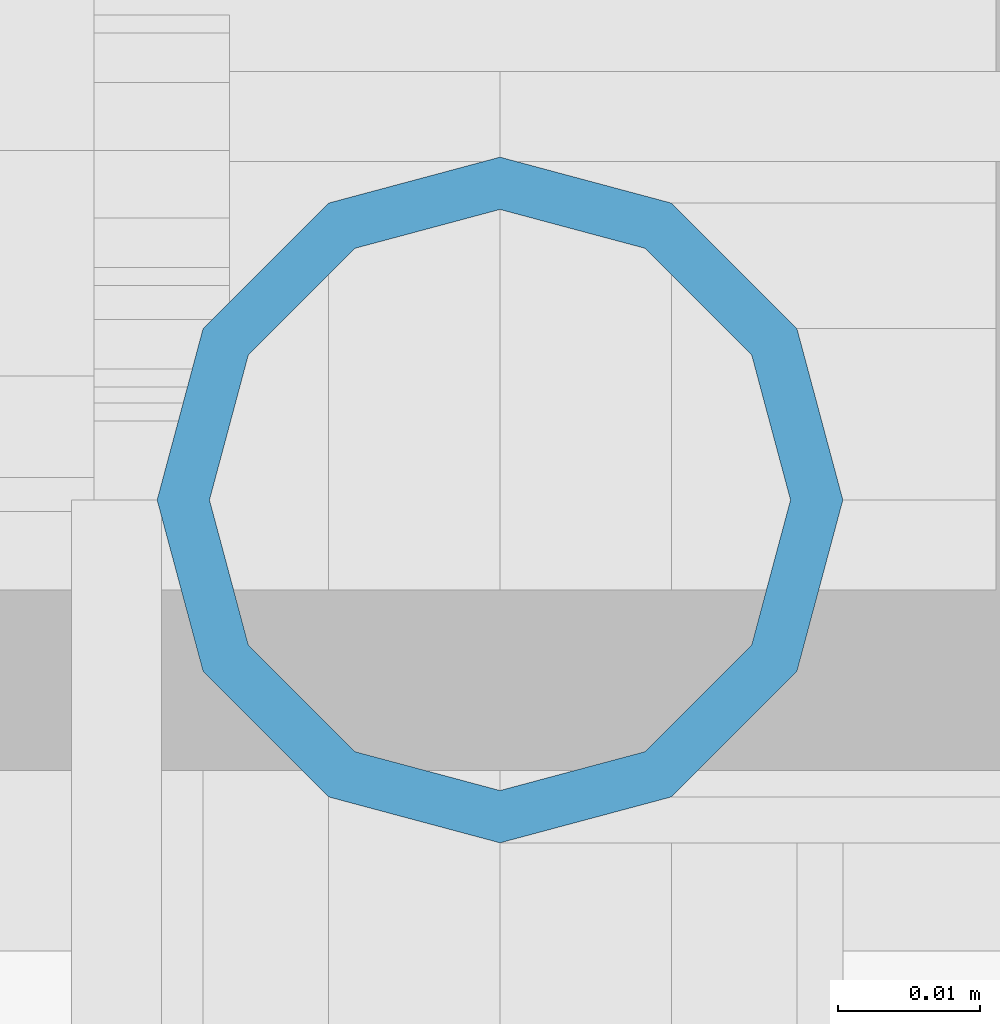
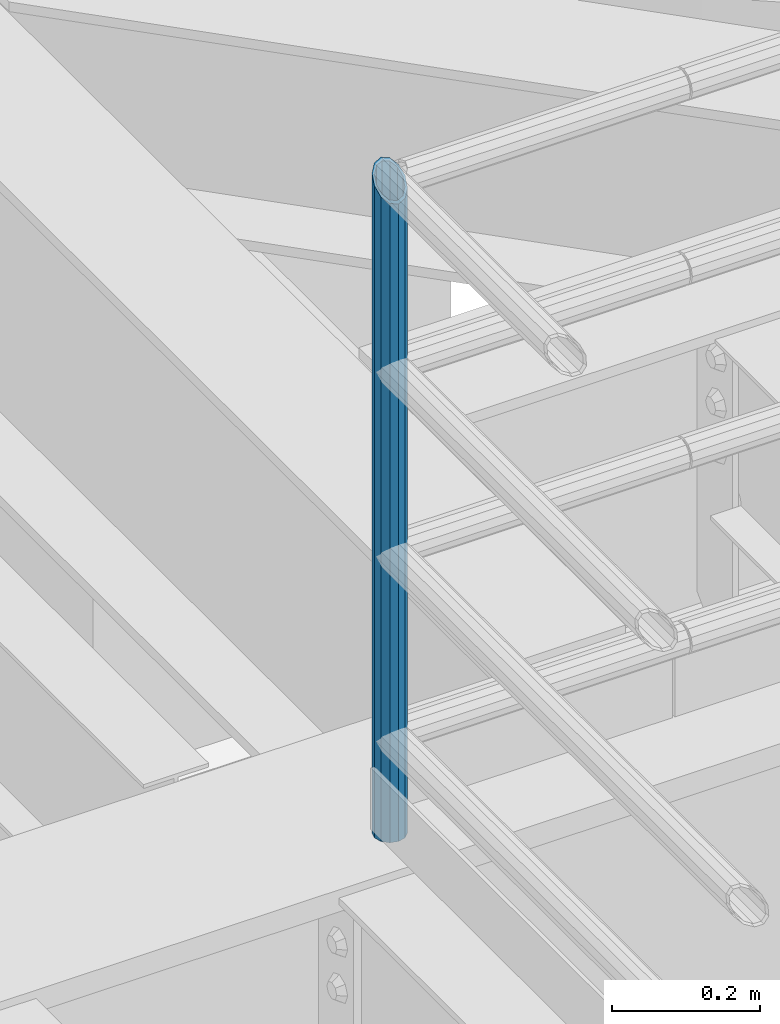
# One storey, part 606 of 1876: 1 column, 1 element without a shape of its own.
"""IFC2X3 building model written with IfcOpenShell, lengths in millimetres."""

from ifc_helpers import new_model, si_unit, frame, origin_with_axes, place, context, subcontext, project, spatial, faceted_brep, material, type_object, element, aggregate, save


model = new_model("IFC2X3")

# Units and contexts
model_context = context("Model", 3, precision=1e-05, world=origin_with_axes())
body_context = subcontext(model_context, "Body", "Model", "MODEL_VIEW")
ifc_project = project(units=[si_unit("LENGTHUNIT", "METRE", prefix="MILLI"), si_unit("AREAUNIT", "SQUARE_METRE"), si_unit("VOLUMEUNIT", "CUBIC_METRE"), si_unit("MASSUNIT", "GRAM", prefix="KILO"), si_unit("TIMEUNIT", "SECOND"), si_unit("PLANEANGLEUNIT", "RADIAN"), si_unit("SOLIDANGLEUNIT", "STERADIAN"), si_unit("THERMODYNAMICTEMPERATUREUNIT", "DEGREE_CELSIUS"), si_unit("LUMINOUSINTENSITYUNIT", "LUMEN")], contexts=[model_context])

# Site, building, storey
site_placement = place(None, origin_with_axes())
site = spatial("IfcSite", under=ifc_project, at=site_placement, CompositionType="ELEMENT")
building_placement = place(site_placement, origin_with_axes())
building = spatial("IfcBuilding", under=site, at=building_placement, Name="Undefined", CompositionType="ELEMENT")
storey_placement = place(building_placement, origin_with_axes())
storey = spatial("IfcBuildingStorey", under=building, at=storey_placement, Name="Undefined", CompositionType="ELEMENT", Elevation=0.0)

# Assembly, column
assembly_placement = place(storey_placement, origin_with_axes())
assembly = element("IfcElementAssembly", 1, at=assembly_placement, inside=storey, Name="RAIL", AssemblyPlace="NOTDEFINED", PredefinedType="RIGID_FRAME")
ifc_material = material()
column_type = type_object("IfcColumnType", Name="PIPE1-1/2SCH40", PredefinedType="NOTDEFINED")
column_placement = place(assembly_placement, frame((1781.175, -4654.55000114554, 8153.4), z_axis=(0.0, 1.0, 0.0), x_axis=(0.0, 0.0, 1.0)))
column = element("IfcColumn", 2, at=column_placement, type_object=column_type, material=ifc_material, Name="POST", ObjectType="PIPE1-1/2SCH40", context=body_context, shape_type="Brep", body=[
    faceted_brep([(0.0, -20.4469999999999, 0.0), (0.0, -17.7076214311803, 10.2235000000001), (1086.54849999999, -17.7076214311801, 10.2235000000001), (1076.325, -20.4469999999999, 0.0), (0.0, -10.2235000000001, 17.7076214311801), (1094.03262143117, -10.2235000000001, 17.7076214311801), (-1.45519152283669e-11, 0.0, 20.4470000000001), (1096.77199999999, 0.0, 20.4470000000001), (0.0, 10.2235000000001, 17.7076214311801), (1094.03262143117, 10.2235000000001, 17.7076214311801), (0.0, 17.7076214311803, 10.2235000000001), (1086.54849999999, 17.7076214311801, 10.2235000000001), (0.0, 20.4469999999999, 0.0), (1076.325, 20.4469999999999, 0.0), (0.0, 17.7076214311803, -10.2235000000001), (1066.10149999999, 17.7076214311801, -10.2235000000001), (0.0, 10.2235000000001, -17.7076214311801), (1058.61737856881, 10.2235000000001, -17.7076214311801), (-1.45519152283669e-11, 0.0, -20.4470000000001), (1055.87799999999, 0.0, -20.4470000000001), (0.0, -10.2235000000001, -17.7076214311801), (1058.61737856881, -10.2235000000001, -17.7076214311801), (0.0, -17.7076214311803, -10.2235000000001), (1066.10149999999, -17.7076214311801, -10.2235000000001), (0.0, -24.1299999999992, 0.0), (0.0, -20.8971929933184, -12.0649999999996), (1064.25999999999, -20.8971929933186, -12.0649999999996), (1076.325, -24.1300000000001, 0.0), (0.0, -12.0650000000001, -20.8971929933186), (1055.42780700667, -12.0649999999996, -20.8971929933186), (-1.45519152283669e-11, 0.0, -24.130000000001), (1052.19499999999, 0.0, -24.1300000000001), (0.0, 12.0650000000001, -20.8971929933186), (1055.42780700667, 12.0649999999996, -20.8971929933186), (0.0, 20.8971929933184, -12.0649999999996), (1064.25999999999, 20.8971929933186, -12.0649999999996), (0.0, 24.1299999999992, 0.0), (1076.325, 24.1300000000001, 0.0), (0.0, 20.8971929933184, 12.0649999999996), (1088.38999999999, 20.8971929933186, 12.0649999999996), (0.0, 12.0650000000001, 20.8971929933186), (1097.22219299331, 12.0649999999996, 20.8971929933186), (-1.45519152283669e-11, 0.0, 24.130000000001), (1100.45499999999, 0.0, 24.1300000000001), (0.0, -12.0650000000001, 20.8971929933186), (1097.22219299331, -12.0649999999996, 20.8971929933186), (0.0, -20.8971929933184, 12.0649999999996), (1088.38999999999, -20.8971929933186, 12.0649999999996)], [[[0, 1, 2, 3]], [[1, 4, 5, 2]], [[4, 6, 7, 5]], [[6, 8, 9, 7]], [[8, 10, 11, 9]], [[10, 12, 13, 11]], [[12, 14, 15, 13]], [[14, 16, 17, 15]], [[16, 18, 19, 17]], [[18, 20, 21, 19]], [[20, 22, 23, 21]], [[22, 0, 3, 23]], [[24, 25, 26, 27]], [[25, 28, 29, 26]], [[28, 30, 31, 29]], [[30, 32, 33, 31]], [[32, 34, 35, 33]], [[34, 36, 37, 35]], [[36, 38, 39, 37]], [[38, 40, 41, 39]], [[40, 42, 43, 41]], [[42, 44, 45, 43]], [[44, 46, 47, 45]], [[46, 24, 27, 47]], [[29, 31, 33, 35, 37, 39, 41, 43, 45, 47, 27, 26], [5, 7, 9, 11, 13, 15, 17, 19, 21, 23, 3, 2]], [[46, 44, 42, 40, 38, 36, 34, 32, 30, 28, 25, 24], [22, 20, 18, 16, 14, 12, 10, 8, 6, 4, 1, 0]]]),
])
aggregate(assembly, [column])

save(model, "model.ifc")
